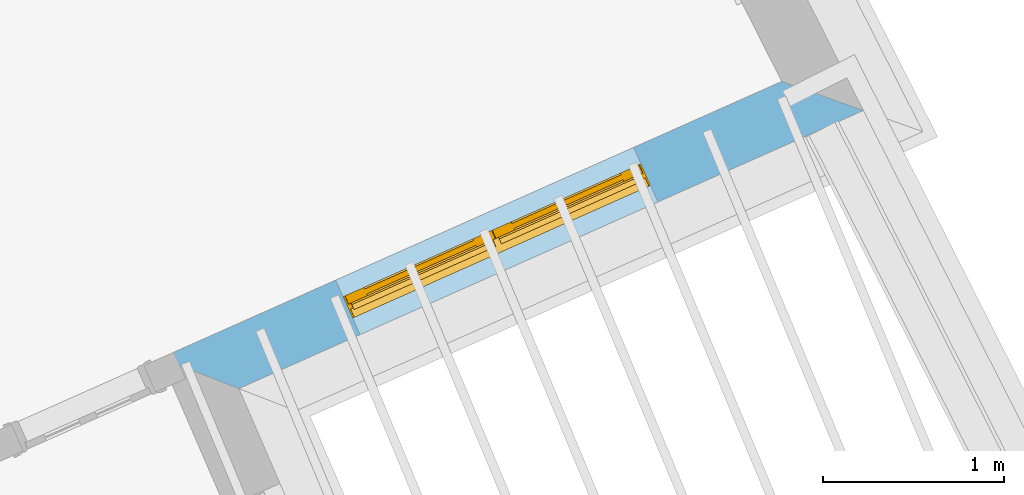
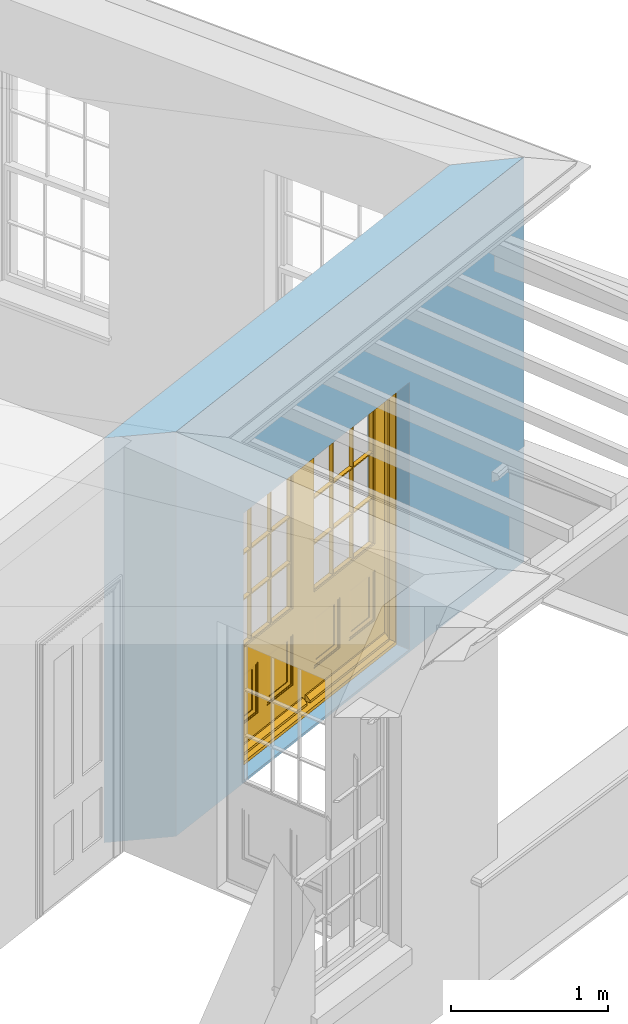
# One storey, part 6 of 10: 1 door, 1 opening, plus 1 element that does not belong to this part.
"""IFC2X3 building model written with IfcOpenShell, lengths in metres."""

from ifc_helpers import new_model, si_unit, frame, origin, place, context, subcontext, project, spatial, polyline, outline, extrude, faceted_brep, material, layer, layer_set, layer_usage, element, fill, save


model = new_model("IFC2X3")

# Units and contexts
model_context = context("Model", 3, world=origin())
body_context = subcontext(model_context, "Body", "Model", "MODEL_VIEW")
ifc_project = project(units=[si_unit("PLANEANGLEUNIT", "RADIAN"), si_unit("MASSUNIT", "GRAM", prefix="KILO"), si_unit("FORCEUNIT", "NEWTON", prefix="KILO"), si_unit("LENGTHUNIT", "METRE")], contexts=[model_context])

# Site, building, storey
site_placement = place(None, origin())
site = spatial("IfcSite", under=ifc_project, at=site_placement, CompositionType="ELEMENT")
building_placement = place(None, origin())
building = spatial("IfcBuilding", under=site, at=building_placement, Name="Building plot-1", CompositionType="ELEMENT")
storey_placement = place(None, frame((0.0, 0.0, 8.45)))
storey = spatial("IfcBuildingStorey", under=building, at=storey_placement, Name="Floor 2", CompositionType="ELEMENT", Elevation=8.45)

# Wall, opening, door
ifc_material = material(Name="Masonry")
ifc_layer = layer(ifc_material, 0.33, ventilated=False)
ifc_layer_set = layer_set([ifc_layer], Name="My Wall")
ifc_layer_usage = layer_usage(ifc_layer_set, "AXIS2", "NEGATIVE", 0.08)
wall_placement = place(storey_placement, origin())
wall = element("IfcWallStandardCase", 1, at=wall_placement, inside=storey, material=ifc_layer_usage, Name="exterior", context=body_context, shape_type="SweptSolid", body=[
    extrude(outline(polyline([(27.617356280873, 45.5560947632642), (28.0499575041078, 45.3875090802526), (31.4968184786281, 46.9225873223324), (31.0458649225511, 47.0829996943095), (27.617356280873, 45.5560947632642)])), origin(), (0.0, 0.0, 1.0), 3.15),
])
opening_placement = place(storey_placement, frame((0.0, 0.0, 0.0199999999999996)))
opening = element("IfcOpeningElement", 2, at=opening_placement, cuts=wall, Name="Opening", ObjectType="Opening", context=body_context, shape_type="SweptSolid", body=[
    extrude(outline(polyline([(28.7182642782321, 45.6851431291963), (30.3625686562166, 46.4174430080309), (30.2283136784303, 46.7188988106614), (28.5840093004458, 45.9865989318268), (28.7182642782321, 45.6851431291963)])), origin(), (0.0, 0.0, 1.0), 2.08),
])
door_placement = place(storey_placement, frame((28.6165559617273, 45.9135187372497, 0.0199999999999996), z_axis=(0.0, 0.0, 1.0), x_axis=(1.64430437798449, 0.732299878834525, 0.0)))
door = element("IfcDoor", 3, at=door_placement, inside=storey, Name="living outside door", OverallHeight=2.08, OverallWidth=1.8, context=body_context, shape_type="Brep", held_by="IfcProductRepresentation", body=[
    faceted_brep([(0.545, -0.055, 0.265), (0.745, -0.055, 0.265), (0.745, -0.05, 0.265), (0.545, -0.05, 0.265), (0.745, -0.05, 0.58), (0.545, -0.05, 0.58), (0.545, -0.055, 0.58), (0.515, -0.06, 0.235), (0.775, -0.06, 0.235), (0.745, -0.055, 0.58), (0.515, -0.06, 0.61), (0.515, -0.065, 0.235), (0.775, -0.065, 0.235), (0.775, -0.06, 0.61), (0.515, -0.065, 0.61), (0.785, -0.065, 0.225), (0.505, -0.065, 0.225), (0.775, -0.065, 0.61), (0.505, -0.065, 0.62), (0.785, -0.065, 0.62), (0.505, -0.07, 0.225), (0.785, -0.07, 0.225), (0.505, -0.07, 0.62), (0.785, -0.07, 0.62), (0.883, -0.07, 0.075), (0.898, -0.07, 0.075), (0.405, -0.07, 0.62), (0.405, -0.07, 0.225), (0.027, -0.07, 0.075), (0.785, -0.07, 0.82), (0.125, -0.07, 0.82), (0.405, -0.065, 0.62), (0.405, -0.065, 0.225), (0.898, -0.07, 2.068), (0.027, -0.08, 0.075), (0.883, -0.08, 0.075), (0.125, -0.07, 0.225), (0.012, -0.07, 0.075), (0.785, -0.06, 0.82), (0.125, -0.06, 0.82), (0.125, -0.07, 0.62), (0.125, -0.065, 0.62), (0.395, -0.065, 0.61), (0.395, -0.065, 0.235), (0.125, -0.065, 0.225), (0.785, -0.07, 1.895), (0.027, -0.11, 0.045), (0.883, -0.11, 0.045), (0.558333, -0.06, 0.83), (0.351667, -0.06, 0.83), (0.125, -0.07, 1.895), (0.125, -0.06, 1.895), (0.785, -0.06, 1.895), (0.012, -0.07, 2.068), (0.135, -0.065, 0.61), (0.395, -0.06, 0.61), (0.395, -0.06, 0.235), (0.135, -0.065, 0.235), (0.027, -0.11, 0.027), (0.883, -0.11, 0.027), (0.568333, -0.06, 0.83), (0.558333, -0.03, 0.83), (0.351667, -0.03, 0.83), (0.341667, -0.06, 0.83), (0.135, -0.06, 1.185), (0.135, -0.06, 1.53), (0.775, -0.06, 1.53), (0.775, -0.06, 1.185), (0.135, -0.06, 0.61), (0.365, -0.055, 0.58), (0.365, -0.055, 0.265), (0.135, -0.06, 0.235), (0.568333, -0.06, 1.175), (0.558333, -0.06, 1.175), (0.775, -0.06, 0.83), (0.558333, -0.03, 1.175), (0.785, -0.03, 0.82), (0.125, -0.03, 0.82), (0.351667, -0.03, 1.175), (0.351667, -0.06, 1.175), (0.341667, -0.06, 1.175), (0.135, -0.06, 0.83), (0.135, -0.06, 1.175), (0.135, -0.03, 1.185), (0.135, -0.03, 1.53), (0.135, -0.06, 1.54), (0.351667, -0.06, 1.885), (0.558333, -0.06, 1.885), (0.775, -0.03, 1.53), (0.775, -0.03, 1.185), (0.775, -0.06, 1.175), (0.775, -0.06, 1.54), (0.165, -0.055, 0.58), (0.365, -0.05, 0.58), (0.365, -0.05, 0.265), (0.165, -0.055, 0.265), (0.568333, -0.03, 0.83), (0.568333, -0.03, 1.175), (0.568333, -0.06, 1.185), (0.558333, -0.06, 1.185), (0.775, -0.03, 0.83), (0.785, -0.02, 0.82), (0.125, -0.02, 0.82), (0.341667, -0.03, 0.83), (0.341667, -0.03, 1.175), (0.351667, -0.06, 1.185), (0.341667, -0.06, 1.185), (0.135, -0.03, 0.83), (0.341667, -0.03, 1.185), (0.125, -0.03, 1.895), (0.341667, -0.03, 1.53), (0.341667, -0.06, 1.53), (0.135, -0.06, 1.885), (0.341667, -0.06, 1.54), (0.341667, -0.06, 1.885), (0.558333, -0.03, 1.885), (0.351667, -0.03, 1.885), (0.568333, -0.06, 1.885), (0.785, -0.03, 1.895), (0.568333, -0.03, 1.185), (0.568333, -0.06, 1.53), (0.568333, -0.03, 1.53), (0.568333, -0.06, 1.54), (0.775, -0.06, 1.885), (0.165, -0.05, 0.58), (0.165, -0.05, 0.265), (0.775, -0.03, 1.175), (0.558333, -0.06, 1.53), (0.351667, -0.03, 1.185), (0.558333, -0.03, 1.185), (0.505, -0.02, 0.62), (0.405, -0.02, 0.62), (0.125, -0.02, 1.895), (0.785, -0.02, 1.895), (0.351667, -0.06, 1.53), (0.135, -0.03, 1.175), (0.135, -0.03, 1.54), (0.341667, -0.03, 1.54), (0.135, -0.03, 1.885), (0.351667, -0.06, 1.54), (0.558333, -0.03, 1.54), (0.558333, -0.06, 1.54), (0.351667, -0.03, 1.54), (0.775, -0.03, 1.54), (0.568333, -0.03, 1.54), (0.775, -0.03, 1.885), (0.558333, -0.03, 1.53), (0.405, -0.02, 0.225), (0.505, -0.02, 0.225), (0.125, -0.02, 0.62), (0.785, -0.02, 0.62), (0.012, -0.02, 2.068), (0.898, -0.02, 2.068), (0.351667, -0.03, 1.53), (0.341667, -0.03, 1.885), (0.568333, -0.03, 1.885), (0.405, -0.025, 0.225), (0.405, -0.025, 0.62), (0.505, -0.025, 0.62), (0.505, -0.025, 0.225), (0.898, -0.02, 0.027), (0.012, -0.02, 0.027), (0.125, -0.025, 0.62), (0.785, -0.025, 0.62), (0.395, -0.025, 0.235), (0.395, -0.025, 0.61), (0.125, -0.02, 0.225), (0.125, -0.025, 0.225), (0.515, -0.025, 0.61), (0.515, -0.025, 0.235), (0.785, -0.02, 0.225), (0.785, -0.025, 0.225), (0.135, -0.025, 0.61), (0.775, -0.025, 0.61), (0.135, -0.025, 0.235), (0.395, -0.03, 0.235), (0.395, -0.03, 0.61), (0.515, -0.03, 0.61), (0.515, -0.03, 0.235), (0.775, -0.025, 0.235), (0.135, -0.03, 0.61), (0.775, -0.03, 0.61), (0.135, -0.03, 0.235), (0.365, -0.035, 0.265), (0.365, -0.035, 0.58), (0.545, -0.035, 0.58), (0.545, -0.035, 0.265), (0.775, -0.03, 0.235), (0.165, -0.035, 0.58), (0.745, -0.035, 0.58), (0.165, -0.035, 0.265), (0.365, -0.04, 0.58), (0.365, -0.04, 0.265), (0.545, -0.04, 0.58), (0.545, -0.04, 0.265), (0.745, -0.035, 0.265), (0.165, -0.04, 0.58), (0.745, -0.04, 0.58), (0.165, -0.04, 0.265), (0.745, -0.04, 0.265), (1.775, -0.072, 0.025), (0.025, -0.072, 0.025), (0.025, -0.1, 0.025), (1.775, -0.1, 0.025), (1.79, -0.02, 0.025), (0.01, -0.02, 0.025), (1.79, -0.072, 0.025), (1.8, -0.02, 0.0), (0.0, -0.02, 0.0), (0.01, -0.072, 0.025), (1.79, -0.072, 2.07), (1.79, -0.02, 2.07), (1.775, -0.072, 2.055), (1.8, -0.02, 2.08), (0.01, -0.02, 2.07), (0.0, -0.02, 2.08), (0.01, -0.072, 2.07), (0.025, -0.072, 2.055), (0.0, -0.15, 2.08), (1.8, -0.15, 2.08), (0.01, -0.15, 2.07), (1.79, -0.15, 2.07), (0.01, -0.1, 2.07), (1.79, -0.1, 2.07), (0.0, -0.15, 0.0), (1.8, -0.15, 0.0), (0.01, -0.15, 0.025), (1.79, -0.15, 0.025), (0.01, -0.1, 0.025), (0.025, -0.1, 2.055), (1.79, -0.1, 0.025), (1.775, -0.1, 2.055), (0.898, -0.07, 0.027), (0.012, -0.07, 0.027), (0.883, -0.07, 0.027), (0.027, -0.07, 0.027), (1.435, -0.055, 0.265), (1.635, -0.055, 0.265), (1.635, -0.05, 0.265), (1.435, -0.05, 0.265), (1.635, -0.05, 0.58), (1.435, -0.05, 0.58), (1.435, -0.055, 0.58), (1.405, -0.06, 0.235), (1.665, -0.06, 0.235), (1.635, -0.055, 0.58), (1.405, -0.06, 0.61), (1.405, -0.065, 0.235), (1.665, -0.065, 0.235), (1.665, -0.06, 0.61), (1.405, -0.065, 0.61), (1.675, -0.065, 0.225), (1.395, -0.065, 0.225), (1.665, -0.065, 0.61), (1.395, -0.065, 0.62), (1.675, -0.065, 0.62), (1.395, -0.07, 0.225), (1.675, -0.07, 0.225), (1.395, -0.07, 0.62), (1.675, -0.07, 0.62), (1.773, -0.07, 0.075), (1.788, -0.07, 0.075), (1.295, -0.07, 0.62), (1.295, -0.07, 0.225), (0.917, -0.07, 0.075), (1.675, -0.07, 0.82), (1.015, -0.07, 0.82), (1.295, -0.065, 0.62), (1.295, -0.065, 0.225), (1.788, -0.07, 2.068), (0.917, -0.08, 0.075), (1.773, -0.08, 0.075), (1.015, -0.07, 0.225), (0.902, -0.07, 0.075), (1.675, -0.06, 0.82), (1.015, -0.06, 0.82), (1.015, -0.07, 0.62), (1.015, -0.065, 0.62), (1.285, -0.065, 0.61), (1.285, -0.065, 0.235), (1.015, -0.065, 0.225), (1.675, -0.07, 1.895), (0.917, -0.11, 0.045), (1.773, -0.11, 0.045), (1.448333, -0.06, 0.83), (1.241667, -0.06, 0.83), (1.015, -0.07, 1.895), (1.015, -0.06, 1.895), (1.675, -0.06, 1.895), (0.902, -0.07, 2.068), (1.025, -0.065, 0.61), (1.285, -0.06, 0.61), (1.285, -0.06, 0.235), (1.025, -0.065, 0.235), (0.917, -0.11, 0.027), (1.773, -0.11, 0.027), (1.458333, -0.06, 0.83), (1.448333, -0.03, 0.83), (1.241667, -0.03, 0.83), (1.231667, -0.06, 0.83), (1.025, -0.06, 1.185), (1.025, -0.06, 1.53), (1.665, -0.06, 1.53), (1.665, -0.06, 1.185), (1.025, -0.06, 0.61), (1.255, -0.055, 0.58), (1.255, -0.055, 0.265), (1.025, -0.06, 0.235), (1.458333, -0.06, 1.175), (1.448333, -0.06, 1.175), (1.665, -0.06, 0.83), (1.448333, -0.03, 1.175), (1.675, -0.03, 0.82), (1.015, -0.03, 0.82), (1.241667, -0.03, 1.175), (1.241667, -0.06, 1.175), (1.231667, -0.06, 1.175), (1.025, -0.06, 0.83), (1.025, -0.06, 1.175), (1.025, -0.03, 1.185), (1.025, -0.03, 1.53), (1.025, -0.06, 1.54), (1.241667, -0.06, 1.885), (1.448333, -0.06, 1.885), (1.665, -0.03, 1.53), (1.665, -0.03, 1.185), (1.665, -0.06, 1.175), (1.665, -0.06, 1.54), (1.055, -0.055, 0.58), (1.255, -0.05, 0.58), (1.255, -0.05, 0.265), (1.055, -0.055, 0.265), (1.458333, -0.03, 0.83), (1.458333, -0.03, 1.175), (1.458333, -0.06, 1.185), (1.448333, -0.06, 1.185), (1.665, -0.03, 0.83), (1.675, -0.02, 0.82), (1.015, -0.02, 0.82), (1.231667, -0.03, 0.83), (1.231667, -0.03, 1.175), (1.241667, -0.06, 1.185), (1.231667, -0.06, 1.185), (1.025, -0.03, 0.83), (1.231667, -0.03, 1.185), (1.015, -0.03, 1.895), (1.231667, -0.03, 1.53), (1.231667, -0.06, 1.53), (1.025, -0.06, 1.885), (1.231667, -0.06, 1.54), (1.231667, -0.06, 1.885), (1.448333, -0.03, 1.885), (1.241667, -0.03, 1.885), (1.458333, -0.06, 1.885), (1.675, -0.03, 1.895), (1.458333, -0.03, 1.185), (1.458333, -0.06, 1.53), (1.458333, -0.03, 1.53), (1.458333, -0.06, 1.54), (1.665, -0.06, 1.885), (1.055, -0.05, 0.58), (1.055, -0.05, 0.265), (1.665, -0.03, 1.175), (1.448333, -0.06, 1.53), (1.241667, -0.03, 1.185), (1.448333, -0.03, 1.185), (1.395, -0.02, 0.62), (1.295, -0.02, 0.62), (1.015, -0.02, 1.895), (1.675, -0.02, 1.895), (1.241667, -0.06, 1.53), (1.025, -0.03, 1.175), (1.025, -0.03, 1.54), (1.231667, -0.03, 1.54), (1.025, -0.03, 1.885), (1.241667, -0.06, 1.54), (1.448333, -0.03, 1.54), (1.448333, -0.06, 1.54), (1.241667, -0.03, 1.54), (1.665, -0.03, 1.54), (1.458333, -0.03, 1.54), (1.665, -0.03, 1.885), (1.448333, -0.03, 1.53), (1.295, -0.02, 0.225), (1.395, -0.02, 0.225), (1.015, -0.02, 0.62), (1.675, -0.02, 0.62), (0.902, -0.02, 2.068), (1.788, -0.02, 2.068), (1.241667, -0.03, 1.53), (1.231667, -0.03, 1.885), (1.458333, -0.03, 1.885), (1.295, -0.025, 0.225), (1.295, -0.025, 0.62), (1.395, -0.025, 0.62), (1.395, -0.025, 0.225), (1.788, -0.02, 0.027), (0.902, -0.02, 0.027), (1.015, -0.025, 0.62), (1.675, -0.025, 0.62), (1.285, -0.025, 0.235), (1.285, -0.025, 0.61), (1.015, -0.02, 0.225), (1.015, -0.025, 0.225), (1.405, -0.025, 0.61), (1.405, -0.025, 0.235), (1.675, -0.02, 0.225), (1.675, -0.025, 0.225), (1.025, -0.025, 0.61), (1.665, -0.025, 0.61), (1.025, -0.025, 0.235), (1.285, -0.03, 0.235), (1.285, -0.03, 0.61), (1.405, -0.03, 0.61), (1.405, -0.03, 0.235), (1.665, -0.025, 0.235), (1.025, -0.03, 0.61), (1.665, -0.03, 0.61), (1.025, -0.03, 0.235), (1.255, -0.035, 0.265), (1.255, -0.035, 0.58), (1.435, -0.035, 0.58), (1.435, -0.035, 0.265), (1.665, -0.03, 0.235), (1.055, -0.035, 0.58), (1.635, -0.035, 0.58), (1.055, -0.035, 0.265), (1.255, -0.04, 0.58), (1.255, -0.04, 0.265), (1.435, -0.04, 0.58), (1.435, -0.04, 0.265), (1.635, -0.035, 0.265), (1.055, -0.04, 0.58), (1.635, -0.04, 0.58), (1.055, -0.04, 0.265), (1.635, -0.04, 0.265), (1.788, -0.07, 0.027), (0.902, -0.07, 0.027), (1.773, -0.07, 0.027), (0.917, -0.07, 0.027)], [[[0, 1, 2, 3]], [[2, 4, 5, 3]], [[0, 3, 5, 6]], [[1, 0, 7, 8]], [[9, 4, 2, 1]], [[9, 6, 5, 4]], [[0, 6, 10, 7]], [[8, 7, 11, 12]], [[8, 13, 9, 1]], [[13, 10, 6, 9]], [[7, 10, 14, 11]], [[15, 12, 11, 16]], [[12, 17, 13, 8]], [[17, 14, 10, 13]], [[18, 16, 11, 14]], [[15, 19, 17, 12]], [[15, 16, 20, 21]], [[14, 17, 19, 18]], [[16, 18, 22, 20]], [[21, 23, 19, 15]], [[24, 25, 21, 20]], [[23, 22, 18, 19]], [[20, 22, 26, 27]], [[23, 21, 25]], [[28, 24, 20, 27]], [[22, 23, 29]], [[29, 30, 26, 22]], [[27, 26, 31, 32]], [[23, 25, 33, 29]], [[34, 35, 24, 28]], [[28, 27, 36, 37]], [[38, 39, 30, 29]], [[26, 30, 40]], [[26, 40, 41, 31]], [[42, 43, 32, 31]], [[32, 44, 36, 27]], [[33, 45, 29]], [[46, 47, 35, 34]], [[36, 40, 37]], [[39, 38, 48, 49]], [[50, 30, 39, 51]], [[29, 45, 52, 38]], [[53, 37, 40, 30]], [[44, 41, 40, 36]], [[31, 41, 54, 42]], [[43, 42, 55, 56]], [[57, 44, 32, 43]], [[50, 45, 33, 53]], [[47, 46, 58, 59]], [[60, 48, 38]], [[49, 48, 61, 62]], [[49, 63, 39]], [[50, 53, 30]], [[51, 39, 64, 65]], [[45, 50, 51, 52]], [[66, 67, 38, 52]], [[57, 54, 41, 44]], [[42, 54, 68, 55]], [[56, 55, 69, 70]], [[56, 71, 57, 43]], [[60, 72, 73, 48]], [[60, 38, 74]], [[48, 73, 75, 61]], [[76, 77, 62, 61]], [[62, 78, 79, 49]], [[49, 79, 80, 63]], [[63, 81, 39]], [[82, 64, 39]], [[65, 64, 83, 84]], [[85, 51, 65]], [[52, 51, 86, 87]], [[88, 89, 67, 66]], [[90, 38, 67]], [[91, 66, 52]], [[71, 68, 54, 57]], [[55, 68, 92, 69]], [[69, 93, 94, 70]], [[70, 95, 71, 56]], [[96, 97, 72, 60]], [[73, 72, 98, 99]], [[74, 38, 90]], [[100, 96, 60, 74]], [[75, 73, 79, 78]], [[61, 75, 97, 96]], [[101, 102, 77, 76]], [[77, 103, 62]], [[96, 76, 61]], [[103, 104, 78, 62]], [[80, 79, 105, 106]], [[63, 80, 104, 103]], [[81, 63, 103, 107]], [[81, 82, 39]], [[106, 64, 82, 80]], [[106, 108, 83, 64]], [[84, 83, 77, 109]], [[110, 111, 65, 84]], [[112, 51, 85]], [[113, 85, 65, 111]], [[114, 86, 51]], [[115, 87, 86, 116]], [[117, 52, 87]], [[118, 76, 89, 88]], [[119, 98, 67, 89]], [[120, 121, 88, 66]], [[67, 98, 72, 90]], [[91, 122, 120, 66]], [[91, 52, 123]], [[95, 92, 68, 71]], [[69, 92, 124, 93]], [[94, 93, 124, 125]], [[94, 125, 95, 70]], [[72, 97, 126, 90]], [[127, 99, 98, 120]], [[99, 105, 79, 73]], [[74, 90, 126, 100]], [[96, 100, 76]], [[128, 129, 75, 78]], [[97, 75, 129, 119]], [[130, 131, 102, 101]], [[109, 77, 102, 132]], [[133, 101, 76, 118]], [[77, 107, 103]], [[78, 104, 108, 128]], [[111, 106, 105, 134]], [[104, 80, 82, 135]], [[107, 135, 82, 81]], [[110, 108, 106, 111]], [[104, 135, 83, 108]], [[83, 135, 77]], [[136, 84, 109]], [[110, 84, 136, 137]], [[114, 51, 112]], [[85, 136, 138, 112]], [[113, 137, 136, 85]], [[111, 134, 139, 113]], [[86, 114, 113, 139]], [[140, 141, 87, 115]], [[139, 142, 116, 86]], [[109, 118, 115, 116]], [[117, 123, 52]], [[117, 87, 141, 122]], [[126, 89, 76]], [[143, 118, 88]], [[120, 98, 119, 121]], [[119, 89, 126, 97]], [[144, 143, 88, 121]], [[144, 122, 91, 143]], [[127, 120, 122, 141]], [[143, 91, 123, 145]], [[124, 92, 95, 125]], [[146, 129, 99, 127]], [[99, 129, 128, 105]], [[100, 126, 76]], [[121, 119, 129, 146]], [[147, 131, 130, 148]], [[131, 149, 102]], [[130, 101, 150]], [[102, 151, 132]], [[118, 109, 132, 133]], [[101, 133, 152]], [[107, 77, 135]], [[153, 128, 108, 110]], [[134, 105, 128, 153]], [[109, 138, 136]], [[153, 110, 137, 142]], [[154, 114, 112, 138]], [[137, 113, 114, 154]], [[141, 139, 134, 127]], [[141, 140, 142, 139]], [[144, 140, 115, 155]], [[142, 137, 154, 116]], [[155, 115, 118]], [[116, 154, 109]], [[117, 155, 145, 123]], [[122, 144, 155, 117]], [[143, 145, 118]], [[121, 146, 140, 144]], [[146, 127, 134, 153]], [[156, 157, 131, 147]], [[148, 130, 158, 159]], [[148, 160, 161, 147]], [[157, 162, 149, 131]], [[161, 151, 102, 149]], [[101, 152, 160, 150]], [[163, 158, 130, 150]], [[151, 152, 133, 132]], [[154, 138, 109]], [[142, 140, 146, 153]], [[145, 155, 118]], [[157, 156, 164, 165]], [[147, 166, 167, 156]], [[168, 169, 159, 158]], [[170, 148, 159, 171]], [[148, 170, 160]], [[166, 147, 161]], [[172, 162, 157, 165]], [[166, 149, 162, 167]], [[166, 161, 149]], [[150, 160, 170]], [[163, 173, 168, 158]], [[171, 163, 150, 170]], [[174, 164, 156, 167]], [[175, 176, 165, 164]], [[169, 168, 177, 178]], [[171, 159, 169, 179]], [[167, 162, 172, 174]], [[176, 180, 172, 165]], [[179, 173, 163, 171]], [[181, 177, 168, 173]], [[164, 174, 182, 175]], [[183, 184, 176, 175]], [[178, 177, 185, 186]], [[179, 169, 178, 187]], [[174, 172, 180, 182]], [[184, 188, 180, 176]], [[187, 181, 173, 179]], [[189, 185, 177, 181]], [[175, 182, 190, 183]], [[191, 184, 183, 192]], [[185, 193, 194, 186]], [[187, 178, 186, 195]], [[182, 180, 188, 190]], [[191, 196, 188, 184]], [[195, 189, 181, 187]], [[197, 193, 185, 189]], [[183, 190, 198, 192]], [[198, 196, 191, 192]], [[194, 193, 197, 199]], [[195, 186, 194, 199]], [[188, 196, 198, 190]], [[197, 189, 195, 199]], [[200, 201, 202, 203]], [[201, 200, 204, 205]], [[206, 204, 200]], [[204, 207, 208, 205]], [[209, 201, 205]], [[210, 211, 204, 206]], [[206, 200, 212, 210]], [[211, 213, 207, 204]], [[214, 205, 208, 215]], [[216, 217, 201, 209]], [[205, 214, 216, 209]], [[216, 214, 211, 210]], [[210, 212, 217, 216]], [[214, 215, 213, 211]], [[218, 219, 213, 215]], [[219, 218, 220, 221]], [[221, 220, 222, 223]], [[215, 208, 224, 218]], [[225, 224, 208, 207]], [[224, 226, 220, 218]], [[224, 225, 227, 226]], [[219, 225, 207, 213]], [[228, 222, 220, 226]], [[219, 221, 227, 225]], [[226, 227, 203, 202]], [[202, 229, 222, 228]], [[228, 226, 202]], [[227, 221, 223, 230]], [[230, 203, 227]], [[217, 229, 202, 201]], [[231, 223, 222, 229]], [[230, 223, 231, 203]], [[231, 229, 217, 212]], [[212, 200, 203, 231]], [[33, 152, 151, 53]], [[25, 160, 152, 33]], [[161, 37, 53, 151]], [[232, 160, 25]], [[161, 233, 37]], [[160, 232, 234]], [[24, 234, 232, 25]], [[233, 161, 235]], [[37, 233, 235, 28]], [[161, 160, 234, 235]], [[35, 47, 234, 24]], [[28, 235, 46, 34]], [[58, 235, 234, 59]], [[59, 234, 47]], [[58, 46, 235]], [[236, 237, 238, 239]], [[238, 240, 241, 239]], [[236, 239, 241, 242]], [[237, 236, 243, 244]], [[245, 240, 238, 237]], [[245, 242, 241, 240]], [[236, 242, 246, 243]], [[244, 243, 247, 248]], [[244, 249, 245, 237]], [[249, 246, 242, 245]], [[243, 246, 250, 247]], [[251, 248, 247, 252]], [[248, 253, 249, 244]], [[253, 250, 246, 249]], [[254, 252, 247, 250]], [[251, 255, 253, 248]], [[251, 252, 256, 257]], [[250, 253, 255, 254]], [[252, 254, 258, 256]], [[257, 259, 255, 251]], [[260, 261, 257, 256]], [[259, 258, 254, 255]], [[256, 258, 262, 263]], [[259, 257, 261]], [[264, 260, 256, 263]], [[258, 259, 265]], [[265, 266, 262, 258]], [[263, 262, 267, 268]], [[259, 261, 269, 265]], [[270, 271, 260, 264]], [[264, 263, 272, 273]], [[274, 275, 266, 265]], [[262, 266, 276]], [[262, 276, 277, 267]], [[278, 279, 268, 267]], [[268, 280, 272, 263]], [[269, 281, 265]], [[282, 283, 271, 270]], [[272, 276, 273]], [[275, 274, 284, 285]], [[286, 266, 275, 287]], [[265, 281, 288, 274]], [[289, 273, 276, 266]], [[280, 277, 276, 272]], [[267, 277, 290, 278]], [[279, 278, 291, 292]], [[293, 280, 268, 279]], [[286, 281, 269, 289]], [[283, 282, 294, 295]], [[296, 284, 274]], [[285, 284, 297, 298]], [[285, 299, 275]], [[286, 289, 266]], [[287, 275, 300, 301]], [[281, 286, 287, 288]], [[302, 303, 274, 288]], [[293, 290, 277, 280]], [[278, 290, 304, 291]], [[292, 291, 305, 306]], [[292, 307, 293, 279]], [[296, 308, 309, 284]], [[296, 274, 310]], [[284, 309, 311, 297]], [[312, 313, 298, 297]], [[298, 314, 315, 285]], [[285, 315, 316, 299]], [[299, 317, 275]], [[318, 300, 275]], [[301, 300, 319, 320]], [[321, 287, 301]], [[288, 287, 322, 323]], [[324, 325, 303, 302]], [[326, 274, 303]], [[327, 302, 288]], [[307, 304, 290, 293]], [[291, 304, 328, 305]], [[305, 329, 330, 306]], [[306, 331, 307, 292]], [[332, 333, 308, 296]], [[309, 308, 334, 335]], [[310, 274, 326]], [[336, 332, 296, 310]], [[311, 309, 315, 314]], [[297, 311, 333, 332]], [[337, 338, 313, 312]], [[313, 339, 298]], [[332, 312, 297]], [[339, 340, 314, 298]], [[316, 315, 341, 342]], [[299, 316, 340, 339]], [[317, 299, 339, 343]], [[317, 318, 275]], [[342, 300, 318, 316]], [[342, 344, 319, 300]], [[320, 319, 313, 345]], [[346, 347, 301, 320]], [[348, 287, 321]], [[349, 321, 301, 347]], [[350, 322, 287]], [[351, 323, 322, 352]], [[353, 288, 323]], [[354, 312, 325, 324]], [[355, 334, 303, 325]], [[356, 357, 324, 302]], [[303, 334, 308, 326]], [[327, 358, 356, 302]], [[327, 288, 359]], [[331, 328, 304, 307]], [[305, 328, 360, 329]], [[330, 329, 360, 361]], [[330, 361, 331, 306]], [[308, 333, 362, 326]], [[363, 335, 334, 356]], [[335, 341, 315, 309]], [[310, 326, 362, 336]], [[332, 336, 312]], [[364, 365, 311, 314]], [[333, 311, 365, 355]], [[366, 367, 338, 337]], [[345, 313, 338, 368]], [[369, 337, 312, 354]], [[313, 343, 339]], [[314, 340, 344, 364]], [[347, 342, 341, 370]], [[340, 316, 318, 371]], [[343, 371, 318, 317]], [[346, 344, 342, 347]], [[340, 371, 319, 344]], [[319, 371, 313]], [[372, 320, 345]], [[346, 320, 372, 373]], [[350, 287, 348]], [[321, 372, 374, 348]], [[349, 373, 372, 321]], [[347, 370, 375, 349]], [[322, 350, 349, 375]], [[376, 377, 323, 351]], [[375, 378, 352, 322]], [[345, 354, 351, 352]], [[353, 359, 288]], [[353, 323, 377, 358]], [[362, 325, 312]], [[379, 354, 324]], [[356, 334, 355, 357]], [[355, 325, 362, 333]], [[380, 379, 324, 357]], [[380, 358, 327, 379]], [[363, 356, 358, 377]], [[379, 327, 359, 381]], [[360, 328, 331, 361]], [[382, 365, 335, 363]], [[335, 365, 364, 341]], [[336, 362, 312]], [[357, 355, 365, 382]], [[383, 367, 366, 384]], [[367, 385, 338]], [[366, 337, 386]], [[338, 387, 368]], [[354, 345, 368, 369]], [[337, 369, 388]], [[343, 313, 371]], [[389, 364, 344, 346]], [[370, 341, 364, 389]], [[345, 374, 372]], [[389, 346, 373, 378]], [[390, 350, 348, 374]], [[373, 349, 350, 390]], [[377, 375, 370, 363]], [[377, 376, 378, 375]], [[380, 376, 351, 391]], [[378, 373, 390, 352]], [[391, 351, 354]], [[352, 390, 345]], [[353, 391, 381, 359]], [[358, 380, 391, 353]], [[379, 381, 354]], [[357, 382, 376, 380]], [[382, 363, 370, 389]], [[392, 393, 367, 383]], [[384, 366, 394, 395]], [[384, 396, 397, 383]], [[393, 398, 385, 367]], [[397, 387, 338, 385]], [[337, 388, 396, 386]], [[399, 394, 366, 386]], [[387, 388, 369, 368]], [[390, 374, 345]], [[378, 376, 382, 389]], [[381, 391, 354]], [[393, 392, 400, 401]], [[383, 402, 403, 392]], [[404, 405, 395, 394]], [[406, 384, 395, 407]], [[384, 406, 396]], [[402, 383, 397]], [[408, 398, 393, 401]], [[402, 385, 398, 403]], [[402, 397, 385]], [[386, 396, 406]], [[399, 409, 404, 394]], [[407, 399, 386, 406]], [[410, 400, 392, 403]], [[411, 412, 401, 400]], [[405, 404, 413, 414]], [[407, 395, 405, 415]], [[403, 398, 408, 410]], [[412, 416, 408, 401]], [[415, 409, 399, 407]], [[417, 413, 404, 409]], [[400, 410, 418, 411]], [[419, 420, 412, 411]], [[414, 413, 421, 422]], [[415, 405, 414, 423]], [[410, 408, 416, 418]], [[420, 424, 416, 412]], [[423, 417, 409, 415]], [[425, 421, 413, 417]], [[411, 418, 426, 419]], [[427, 420, 419, 428]], [[421, 429, 430, 422]], [[423, 414, 422, 431]], [[418, 416, 424, 426]], [[427, 432, 424, 420]], [[431, 425, 417, 423]], [[433, 429, 421, 425]], [[419, 426, 434, 428]], [[434, 432, 427, 428]], [[430, 429, 433, 435]], [[431, 422, 430, 435]], [[424, 432, 434, 426]], [[433, 425, 431, 435]], [[269, 388, 387, 289]], [[261, 396, 388, 269]], [[397, 273, 289, 387]], [[436, 396, 261]], [[397, 437, 273]], [[396, 436, 438]], [[260, 438, 436, 261]], [[437, 397, 439]], [[273, 437, 439, 264]], [[397, 396, 438, 439]], [[271, 283, 438, 260]], [[264, 439, 282, 270]], [[294, 439, 438, 295]], [[295, 438, 283]], [[294, 282, 439]]]),
])
fill(opening, door)

save(model, "model.ifc")
